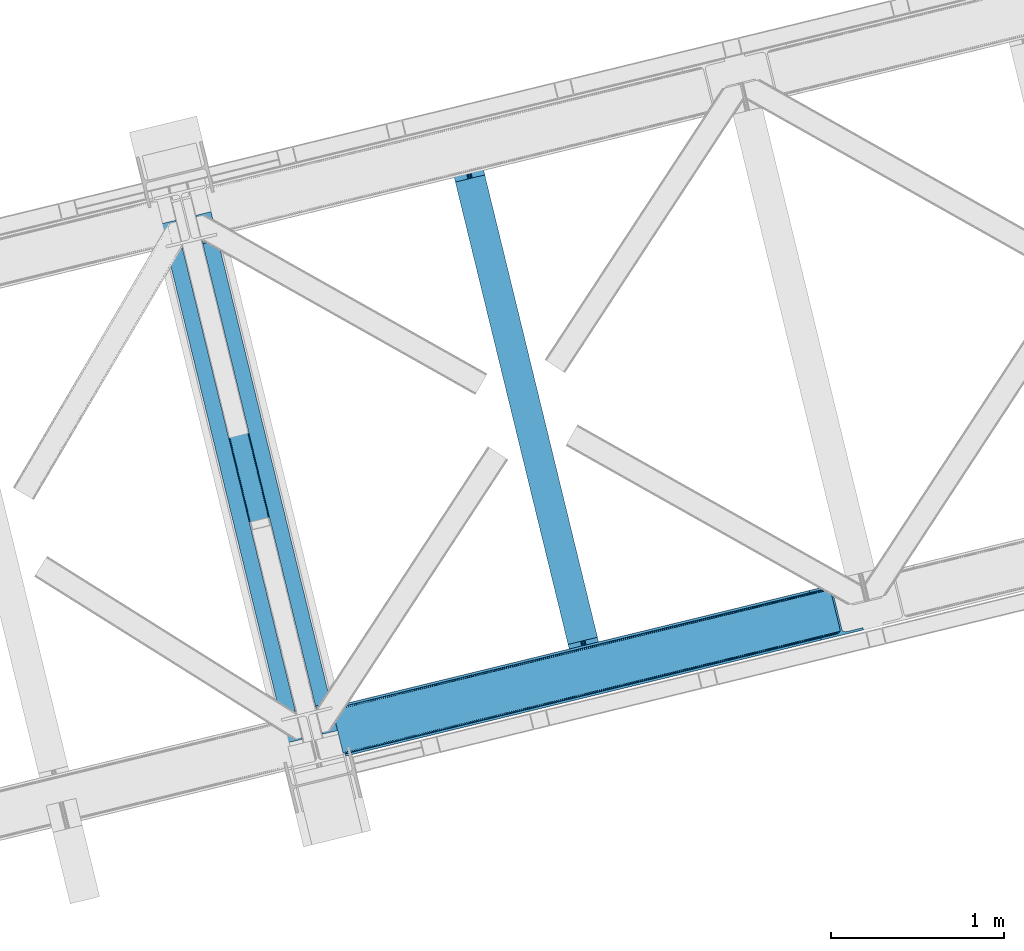
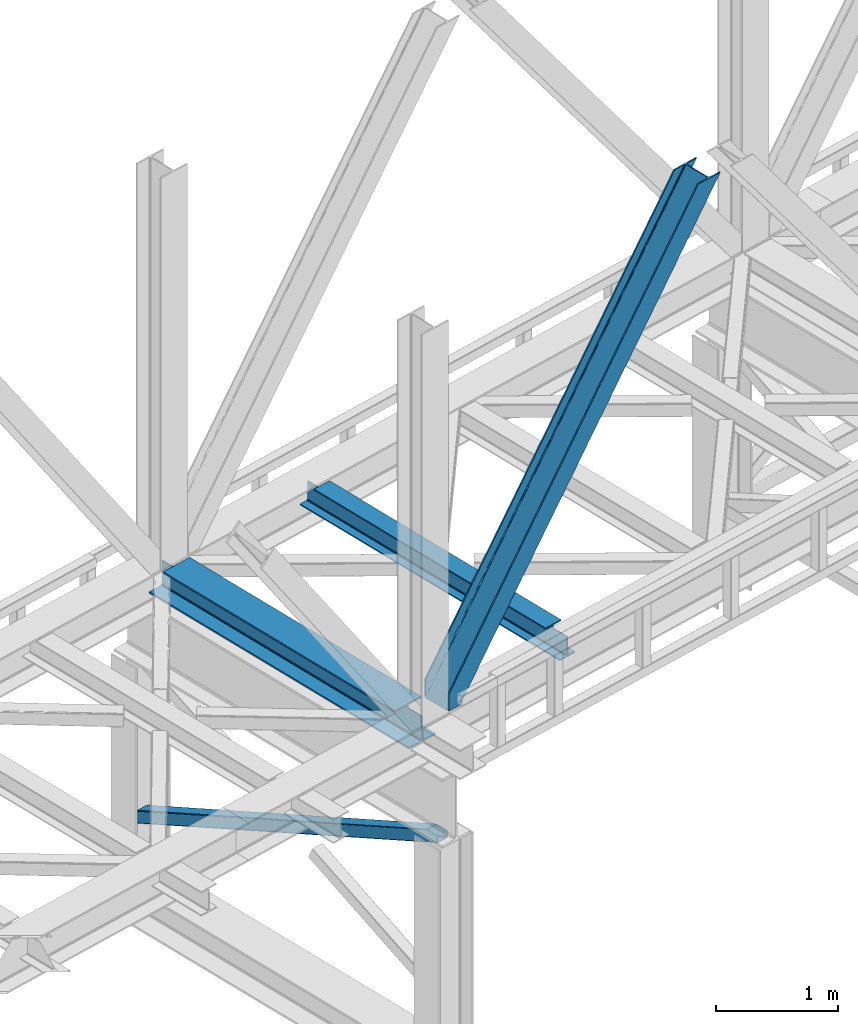
# One storey, part 38 of 92: 2 beams, 2 members.
"""IFC4 building model written with IfcOpenShell, lengths in millimetres."""

import ifcopenshell
import ifcopenshell.guid

model = None  # the IFC model being written
_history = None  # IfcOwnerHistory: only IFC2X3 demands one
_inside = {}  # id of a spatial element -> (the spatial element, [elements in it])
_under = {}  # id of a project, library or spatial element -> (it, [spatial elements below it])
_declared = {}  # id of a project -> (the project, [libraries it declares])
_typed = {}  # id of a type object -> (the type object, [elements of that type])
_made_of = {}  # id of a material, layer set ... -> (it, [elements and type objects made of it])


def new_model(schema):
    """Start an empty IFC model of exactly this schema.

    Asked for "IFC4X3", IfcOpenShell would pick the latest addendum, in which some entities
    have other attributes; the version numbers below select the first issue.
    IFC2X3 requires an IfcOwnerHistory on every rooted entity: one is made here for all.
    """
    global model, _history
    if schema == "IFC4X3":
        model = ifcopenshell.file(schema_version=(4, 3, 0, 0))
    else:
        model = ifcopenshell.file(schema=schema)
    _inside.clear()
    _under.clear()
    _declared.clear()
    _typed.clear()
    _made_of.clear()
    _history = None
    if model.schema == "IFC2X3":
        org = make("IfcOrganization", Name="unknown")
        user = make(
            "IfcPersonAndOrganization",
            ThePerson=make("IfcPerson", FamilyName="unknown"),
            TheOrganization=org,
        )
        app = make(
            "IfcApplication",
            ApplicationDeveloper=org,
            Version="unknown",
            ApplicationFullName="unknown",
            ApplicationIdentifier="unknown",
        )
        _history = make(
            "IfcOwnerHistory",
            OwningUser=user,
            OwningApplication=app,
            ChangeAction="ADDED",
            CreationDate=0,
        )
    return model


def make(cls, **values):
    """One entity of the class cls with the attributes given. An attribute that is None is left unset."""
    return model.create_entity(
        cls, **{name: value for name, value in values.items() if value is not None}
    )


def entity(cls, *values):
    """Any entity or typed value of the class cls, its attributes in the order of the schema. None: left unset."""
    e = model.create_entity(cls)
    for i, value in enumerate(values):
        if value is not None:
            e[i] = value
    return e


def rooted(cls, **values):
    """An entity with a GlobalId (a new one), such as an element, a storey or a relation."""
    return make(cls, GlobalId=ifcopenshell.guid.new(), OwnerHistory=_history, **values)


def si_unit(unit_type, name, prefix=None):
    """IfcSIUnit, for example si_unit("LENGTHUNIT", "METRE", prefix="MILLI")."""
    return make("IfcSIUnit", UnitType=unit_type, Prefix=prefix, Name=name)


def converted_unit(unit_type, name, factor, base, dimensions=None, offset=None):
    """IfcConversionBasedUnit, such as the inch: factor (a typed value) times the base unit."""
    return make(
        "IfcConversionBasedUnit"
        if offset is None
        else "IfcConversionBasedUnitWithOffset",
        ConversionOffset=offset,
        Dimensions=None
        if dimensions is None
        else entity("IfcDimensionalExponents", *dimensions),
        UnitType=unit_type,
        Name=name,
        ConversionFactor=make(
            "IfcMeasureWithUnit", ValueComponent=factor, UnitComponent=base
        ),
    )


def derived_unit(unit_type, elements):
    """IfcDerivedUnit: a product of units, each with its exponent."""
    return make(
        "IfcDerivedUnit",
        Elements=[
            make("IfcDerivedUnitElement", Unit=unit, Exponent=power)
            for unit, power in elements
        ],
        UnitType=unit_type,
    )


def assignment(units):
    """IfcUnitAssignment: the units of a project."""
    return None if units is None else make("IfcUnitAssignment", Units=units)


def point(xyz):
    """IfcCartesianPoint."""
    return None if xyz is None else make("IfcCartesianPoint", Coordinates=xyz)


def direction(xyz):
    """IfcDirection."""
    return None if xyz is None else make("IfcDirection", DirectionRatios=xyz)


def frame(location, z_axis=None, x_axis=None):
    """IfcAxis2Placement3D, a coordinate frame: its origin and axes. An axis left out is left unset."""
    return make(
        "IfcAxis2Placement3D",
        Location=point(location),
        Axis=direction(z_axis),
        RefDirection=direction(x_axis),
    )


def origin():
    """The frame at (0, 0, 0) with its axes left unset."""
    return frame((0.0, 0.0, 0.0))


def place(relative_to, where):
    """IfcLocalPlacement: puts the frame where relative to a parent placement (None: the world)."""
    return make(
        "IfcLocalPlacement", PlacementRelTo=relative_to, RelativePlacement=where
    )


def context(
    kind, dimensions, precision=None, world=None, true_north=None, identifier=None
):
    """IfcGeometricRepresentationContext, for example the 3D "Model" context."""
    return make(
        "IfcGeometricRepresentationContext",
        ContextIdentifier=identifier,
        ContextType=kind,
        CoordinateSpaceDimension=dimensions,
        Precision=precision,
        WorldCoordinateSystem=world,
        TrueNorth=true_north,
    )


def subcontext(parent, identifier, kind, view, scale=None):
    """IfcGeometricRepresentationSubContext, for example "Body" below "Model"."""
    return make(
        "IfcGeometricRepresentationSubContext",
        ContextIdentifier=identifier,
        ContextType=kind,
        ParentContext=parent,
        TargetScale=scale,
        TargetView=view,
    )


def project(units=None, contexts=None):
    """IfcProject with its units and contexts."""
    return rooted(
        "IfcProject",
        Name="project",
        RepresentationContexts=contexts,
        UnitsInContext=assignment(units),
    )


def spatial(cls, under=None, at=None, **own):
    """A site, building, storey or space (cls), placed at a placement, below another one or the project."""
    s = rooted(cls, ObjectPlacement=at, **own)
    if under is not None:
        _under.setdefault(under.id(), (under, []))[1].append(s)
    return s


def point_list(points):
    """IfcCartesianPointList2D or 3D."""
    cls = (
        "IfcCartesianPointList2D" if len(points[0]) == 2 else "IfcCartesianPointList3D"
    )
    return make(cls, CoordList=points)


def triangles(points, corners, closed=None, point_numbers=None):
    """IfcTriangulatedFaceSet: each triangle names its three corners, points numbered from 1."""
    return make(
        "IfcTriangulatedFaceSet",
        Coordinates=point_list(points),
        Closed=closed,
        CoordIndex=corners,
        PnIndex=point_numbers,
    )


def polygons(points, faces, closed=None, point_numbers=None):
    """IfcPolygonalFaceSet: a face is its outer loop, then its inner loops; points numbered from 1."""
    made = []
    for loops in faces:
        if len(loops) == 1:
            made.append(make("IfcIndexedPolygonalFace", CoordIndex=loops[0]))
        else:
            made.append(
                make(
                    "IfcIndexedPolygonalFaceWithVoids",
                    CoordIndex=loops[0],
                    InnerCoordIndices=loops[1:],
                )
            )
    return make(
        "IfcPolygonalFaceSet",
        Coordinates=point_list(points),
        Closed=closed,
        Faces=made,
        PnIndex=point_numbers,
    )


def shape(context_of_items, identifier, shape_type, items):
    """IfcShapeRepresentation: the items that make up one representation, for example the "Body"."""
    return make(
        "IfcShapeRepresentation",
        ContextOfItems=context_of_items,
        RepresentationIdentifier=identifier,
        RepresentationType=shape_type,
        Items=items,
    )


def material(Name=None, Category=None):
    """IfcMaterial."""
    return make("IfcMaterial", Name=Name, Category=Category)


def made_of(thing, what):
    """Note that an element or type object is made of a material, layer set ...; save() writes the relation."""
    if what is not None:
        _made_of.setdefault(what.id(), (what, []))[1].append(thing)
    return thing


def type_object(cls, material=None, **own):
    """A type object (cls), such as IfcWallType, which elements share."""
    return made_of(rooted(cls, **own), material)


def element(
    cls,
    number,
    at=None,
    inside=None,
    cuts=None,
    type_object=None,
    material=None,
    context=None,
    identifier="Body",
    shape_type=None,
    held_by="IfcProductDefinitionShape",
    body=None,
    shapes=None,
    **own,
):
    """One element of the class cls, such as IfcWall. Its Tag is "e" and its number.

    at: its placement. inside: the storey or other place that contains it. cuts: it is an
    opening in that element (IfcRelVoidsElement). A single representation is given by context,
    identifier, shape_type and body (its items); several are given by shapes. held_by: the class
    of the entity that holds the representations. save() writes the other relations.
    """
    e = rooted(cls, Tag="e%d" % number, ObjectPlacement=at, **own)
    if body is not None:
        shapes = [shape(context, identifier, shape_type, body)]
    if shapes is not None:
        e.Representation = make(held_by, Representations=shapes)
    if inside is not None:
        _inside.setdefault(inside.id(), (inside, []))[1].append(e)
    if cuts is not None:
        rooted(
            "IfcRelVoidsElement", RelatingBuildingElement=cuts, RelatedOpeningElement=e
        )
    if type_object is not None:
        _typed.setdefault(type_object.id(), (type_object, []))[1].append(e)
    return made_of(e, material)


def aggregate(whole, parts):
    """IfcRelAggregates: a whole, such as a stair, and the parts it consists of."""
    return rooted("IfcRelAggregates", RelatingObject=whole, RelatedObjects=parts)


def save(model, path):
    """Write the relations noted so far, then the file.

    IfcRelAggregates (storeys below a building ...), IfcRelContainedInSpatialStructure (elements
    in a storey), IfcRelDefinesByType, IfcRelAssociatesMaterial and IfcRelDeclares: one each for
    every whole, place, type object, material and project.
    """
    for whole, parts in _under.values():
        aggregate(whole, parts)
    for where, things in _inside.values():
        rooted(
            "IfcRelContainedInSpatialStructure",
            RelatedElements=things,
            RelatingStructure=where,
        )
    for kind, things in _typed.values():
        rooted("IfcRelDefinesByType", RelatedObjects=things, RelatingType=kind)
    for what, things in _made_of.values():
        rooted("IfcRelAssociatesMaterial", RelatedObjects=things, RelatingMaterial=what)
    for by, libraries in _declared.values():
        rooted("IfcRelDeclares", RelatingContext=by, RelatedDefinitions=libraries)
    model.write(path)


model = new_model("IFC4")

# Units and contexts
model_context = context("Model", 3, precision=0.01, world=origin(), true_north=direction((6.12303176911189e-17, 1.0)))
plan_context = context("Plan", 3, precision=0.01, world=origin(), true_north=direction((6.12303176911189e-17, 1.0)))
body_context = subcontext(model_context, "Body", "Model", "MODEL_VIEW")
ifc_project = project(units=[si_unit("LENGTHUNIT", "METRE", prefix="MILLI"), si_unit("AREAUNIT", "SQUARE_METRE"), si_unit("VOLUMEUNIT", "CUBIC_METRE"), converted_unit("PLANEANGLEUNIT", "DEGREE", entity("IfcRatioMeasure", 0.0174532925199433), si_unit("PLANEANGLEUNIT", "RADIAN"), dimensions=[0, 0, 0, 0, 0, 0, 0]), si_unit("MASSUNIT", "GRAM", prefix="KILO"), derived_unit("MASSDENSITYUNIT", [(si_unit("MASSUNIT", "GRAM", prefix="KILO"), 1), (si_unit("LENGTHUNIT", "METRE"), -3)]), derived_unit("MOMENTOFINERTIAUNIT", [(si_unit("LENGTHUNIT", "METRE"), 4)]), si_unit("TIMEUNIT", "SECOND"), si_unit("FREQUENCYUNIT", "HERTZ"), si_unit("THERMODYNAMICTEMPERATUREUNIT", "DEGREE_CELSIUS"), derived_unit("THERMALTRANSMITTANCEUNIT", [(si_unit("MASSUNIT", "GRAM", prefix="KILO"), 1), (si_unit("THERMODYNAMICTEMPERATUREUNIT", "KELVIN"), -1), (si_unit("TIMEUNIT", "SECOND"), -3)]), derived_unit("VOLUMETRICFLOWRATEUNIT", [(si_unit("LENGTHUNIT", "METRE"), 3), (si_unit("TIMEUNIT", "SECOND"), -1)]), derived_unit("MASSFLOWRATEUNIT", [(si_unit("MASSUNIT", "GRAM", prefix="KILO"), 1), (si_unit("TIMEUNIT", "SECOND"), -1)]), derived_unit("ROTATIONALFREQUENCYUNIT", [(si_unit("TIMEUNIT", "SECOND"), -1)]), si_unit("ELECTRICCURRENTUNIT", "AMPERE"), si_unit("ELECTRICVOLTAGEUNIT", "VOLT"), si_unit("POWERUNIT", "WATT"), si_unit("FORCEUNIT", "NEWTON", prefix="KILO"), si_unit("ILLUMINANCEUNIT", "LUX"), si_unit("LUMINOUSFLUXUNIT", "LUMEN"), si_unit("LUMINOUSINTENSITYUNIT", "CANDELA"), derived_unit("USERDEFINED", [(si_unit("MASSUNIT", "GRAM", prefix="KILO"), -1), (si_unit("LENGTHUNIT", "METRE"), -2), (si_unit("TIMEUNIT", "SECOND"), 3), (si_unit("LUMINOUSFLUXUNIT", "LUMEN"), 1)]), derived_unit("LINEARVELOCITYUNIT", [(si_unit("LENGTHUNIT", "METRE"), 1), (si_unit("TIMEUNIT", "SECOND"), -1)]), si_unit("PRESSUREUNIT", "PASCAL"), derived_unit("USERDEFINED", [(si_unit("LENGTHUNIT", "METRE"), -2), (si_unit("MASSUNIT", "GRAM", prefix="KILO"), 1), (si_unit("TIMEUNIT", "SECOND"), -2)]), derived_unit("LINEARFORCEUNIT", [(si_unit("MASSUNIT", "GRAM", prefix="KILO"), 1), (si_unit("LENGTHUNIT", "METRE"), 1), (si_unit("TIMEUNIT", "SECOND"), -2), (si_unit("LENGTHUNIT", "METRE"), -1)]), derived_unit("PLANARFORCEUNIT", [(si_unit("MASSUNIT", "GRAM", prefix="KILO"), 1), (si_unit("LENGTHUNIT", "METRE"), 1), (si_unit("TIMEUNIT", "SECOND"), -2), (si_unit("LENGTHUNIT", "METRE"), -2)])], contexts=[model_context, plan_context])

# Site, building, storey
site_placement = place(None, origin())
site = spatial("IfcSite", under=ifc_project, at=site_placement, CompositionType="ELEMENT")
building_placement = place(site_placement, origin())
building = spatial("IfcBuilding", under=site, at=building_placement, CompositionType="ELEMENT")
storey_placement = place(building_placement, frame((0.0, 0.0, 15900.0)))
storey = spatial("IfcBuildingStorey", under=building, at=storey_placement, Name="05", CompositionType="ELEMENT", Elevation=15900.0)

# Beams
ifc_material = material(Name="Metal painted (White)")
beam_type = type_object("IfcBeamType", PredefinedType="BEAM")
beam_1_placement = place(storey_placement, frame((-49495.31, 5721.7, 3385.0)))
element("IfcBeam", 1, at=beam_1_placement, inside=storey, type_object=beam_type, material=ifc_material, ObjectType="Steel Beam", PredefinedType="BEAM", context=body_context, shape_type="Tessellation", body=[
    polygons([(1022.42935345713, 71.0478278971021, 15.4999999999986), (1022.42935345713, 71.0478278971021, 0.0), (291.465617442446, 3069.74325535076, 0.0), (291.465617442455, 3069.74325535076, 15.4999999999986), (899.04224207317, 40.9709140873291, 15.4999999999986), (168.078506058491, 3039.66634154099, 15.4999999999986), (892.349898299208, 39.3395844888232, 16.8701684147963), (161.386162284528, 3038.03501194248, 16.8701684147963), (886.676403198592, 37.956610033653, 20.7720779386413), (155.712667183913, 3036.65203748731, 20.7720779386413), (882.885494970017, 37.0325360459173, 26.6116982174294), (151.921758955338, 3035.72796349958, 26.6116982174294), (881.554305026612, 36.708044413504, 33.500000000001), (150.590569011941, 3035.40347186716, 33.500000000001), (140.875048430522, 3033.03521093726, 33.500000000001), (140.875048430522, 3033.03521093726, 259.000000000002), (150.590569011932, 3035.40347186716, 259.000000000002), (0.0, 2998.69542745366, 0.0), (0.0, 2998.69542745366, 15.4999999999986), (123.387111383972, 3028.77234126343, 15.4999999999986), (130.079455157926, 3030.40367086194, 16.8701684147963), (135.752950258551, 3031.78664531711, 20.7720779386413), (139.543858487135, 3032.71071930484, 26.6116982174294), (881.554305026612, 36.708044413504, 259.000000000002), (871.838784445202, 34.3397834835992, 259.000000000002), (871.838784445202, 34.3397834836003, 33.500000000001), (870.507594501796, 34.0152918511837, 26.6116982174294), (866.716686273221, 33.0912178634492, 20.7720779386413), (861.043191172606, 31.7082434082778, 16.8701684147963), (854.350847398643, 30.076913809773, 15.4999999999986), (730.963736014679, 0.0, 15.4999999999986), (730.963736014679, 0.0, 0.0), (841.85453458624, 199.571930111231, 259.069791776412), (190.199733064572, 2872.911390143, 259.000000000002), (190.423126166413, 2871.99494573803, 259.61730333112), (190.435515010047, 2871.94412150426, 266.500003008253), (841.70935577274, 200.167408132525, 266.500002998871), (841.709705893492, 200.16597182779, 260.000004007589), (832.229597305445, 196.831858094285, 259.006343172366), (832.006227290721, 197.74830961273, 259.61730333112), (831.993838447078, 197.799133846505, 266.500003008253), (180.719997684385, 2869.57584721824, 266.500002998871), (180.719647563633, 2869.57728352297, 260.000004007589), (180.574841905298, 2870.17133233676, 259.07612046749), (180.484212483145, 2870.5431292131, 259.000000000002), (843.040843642667, 200.490677577209, 273.388305639783), (846.831120231363, 201.417342749122, 279.227924098781), (852.504191178902, 202.802057212798, 283.129832400615), (859.196382860027, 204.434010743612, 284.500000377228), (982.583411547871, 234.511263798724, 284.500000138971), (982.581741741219, 234.518113867455, 299.999995328161), (691.11631964394, 163.469484603412, 299.999995890962), (691.1179894506, 163.46263453468, 284.500000701776), (814.505018138444, 193.539887589791, 284.500000463519), (821.197505034583, 195.17063005637, 283.129832461069), (826.871416683352, 196.551895700895, 279.227924137322), (830.662951470335, 197.473399350194, 273.388305663684), (179.38850981445, 2869.25257777355, 273.388305639783), (175.598233225762, 2868.32591260164, 279.227924098781), (169.925162278224, 2866.94119813796, 283.129832400619), (163.232970597099, 2865.30924460715, 284.500000377228), (39.8459419092548, 2835.23199155204, 284.500000138971), (39.8476117159152, 2835.22514148331, 299.999995328161), (331.313033813185, 2906.27377074735, 299.999995890962), (331.311364006525, 2906.28062081608, 284.500000701776), (207.92433531869, 2876.20336776097, 284.500000463519), (201.231848422542, 2874.57262529439, 283.129832461065), (195.557936773782, 2873.19135964986, 279.227924137322), (191.76640198679, 2872.26985600057, 273.388305663684)], [[[1, 2, 3, 4]], [[5, 1, 4, 6]], [[7, 5, 6, 8]], [[9, 7, 8, 10]], [[11, 9, 10, 12]], [[13, 11, 12, 14]], [[15, 16, 17, 14, 12, 10, 8, 6, 4, 3, 18, 19, 20, 21, 22, 23]], [[13, 24, 25, 26, 27, 28, 29, 30, 31, 32, 2, 1, 5, 7, 9, 11]], [[2, 32, 18, 3]], [[32, 31, 19, 18]], [[31, 30, 20, 19]], [[27, 26, 15, 23]], [[28, 27, 23, 22]], [[29, 28, 22, 21]], [[30, 29, 21, 20]], [[33, 24, 13, 14, 17, 34, 35, 36, 37, 38]], [[25, 39, 40, 41, 42, 43, 44, 16, 15, 26]], [[39, 25, 24, 33]], [[45, 34, 17, 16]], [[41, 40, 38, 37, 46, 47, 48, 49, 50, 51, 52, 53, 54, 55, 56, 57]], [[42, 58, 59, 60, 61, 62, 63, 64, 65, 66, 67, 68, 69, 36, 35, 43]], [[46, 37, 36, 69]], [[47, 46, 69, 68]], [[48, 47, 68, 67]], [[49, 48, 67, 66]], [[50, 49, 66, 65]], [[51, 50, 65, 64]], [[52, 51, 64, 63]], [[53, 52, 63, 62]], [[54, 53, 62, 61]], [[55, 54, 61, 60]], [[56, 55, 60, 59]], [[57, 56, 59, 58]], [[41, 57, 58, 42]]], closed=False),
])
beam_2_placement = place(storey_placement, frame((-47831.53, 6127.26, 3441.0)))
element("IfcBeam", 2, at=beam_2_placement, inside=storey, type_object=beam_type, material=ifc_material, ObjectType="Steel Beam", PredefinedType="BEAM", context=body_context, shape_type="Tessellation", body=[
    polygons([(900.98534618944, 41.4445662733081, 11.000000000004), (900.98534618944, 41.4445662733081, 2.16573425859679e-12), (170.021610174761, 3040.13999372697, 2.16573425859679e-12), (170.021610174761, 3040.13999372697, 11.000000000004), (834.919806235823, 25.3403919499656, 11.000000000004), (103.956070221144, 3024.03581940362, 11.000000000004), (828.971056214531, 23.8903211957396, 12.2179274798217), (98.0073201998513, 3022.5857486494, 12.2179274798217), (823.927949458422, 22.6610105689183, 15.6862915010192), (92.9642134437427, 3021.35643802258, 15.6862915010192), (820.558253255246, 21.8396114687108, 20.8770650821657), (89.5945172405668, 3020.53503892237, 20.8770650821657), (819.37497330556, 21.5511744621195, 27.0000000000047), (88.4112372908809, 3020.24660191578, 27.0000000000047), (81.6103728838888, 3018.58881926485, 27.0000000000047), (81.6103728838888, 3018.58881926485, 203.000000000006), (88.4112372908809, 3020.24660191578, 203.000000000006), (8.66293703438714e-12, 2998.69542745366, 2.16573425859679e-12), (8.66293703438714e-12, 2998.69542745366, 10.9999999999997), (66.0655399536259, 3014.799601777, 11.000000000004), (72.014289974927, 3016.24967253123, 12.2179274798217), (77.057396731027, 3017.47898315805, 15.6862915010192), (80.4270929342029, 3018.30038225826, 20.8770650821657), (819.374973305552, 21.5511744621206, 203.000000000006), (812.574108898559, 19.8933918111876, 203.000000000006), (812.574108898559, 19.8933918111876, 27.0000000000047), (811.390828948873, 19.6049548045974, 20.8770650821657), (808.021132745698, 18.7835557043887, 15.6862915010192), (802.978025989598, 17.5542450775685, 12.2179274798217), (797.029275968296, 16.1041743233425, 11.000000000004), (730.963736014679, -1.08286712929839e-12, 10.9999999999997), (730.963736014679, -1.08286712929839e-12, 2.16573425859679e-12), (779.675212882757, 184.415062601693, 203.069791966819), (128.020401343512, 2857.75452019162, 203.000000000006), (128.243282132658, 2856.84017775719, 203.617301946336), (128.256196377177, 2856.7871977843, 217.000003693143), (779.530009633833, 185.010597404072, 217.000003676718), (779.530880241731, 185.007025963192, 204.00000679514), (772.96491171832, 182.385463974442, 203.006342981529), (772.742064056782, 183.299815969774, 203.617301946336), (772.729149812263, 183.352795942667, 217.000003693143), (121.455336555608, 2855.1293963229, 217.000003676718), (121.45446594771, 2855.13296776378, 204.00000679514), (121.310166358664, 2855.72494066435, 203.076120467494), (121.21953693652, 2856.09673754069, 203.000000000006), (780.713494357868, 185.298194377513, 223.122939328039), (784.082490766547, 186.122464201392, 228.313710402595), (789.125126170571, 187.353708426697, 231.782072735464), (795.073705041275, 188.80448128138, 232.999999602236), (861.13915590679, 204.909021065315, 232.999999283132), (861.137682570361, 204.915065042187, 243.999994005812), (691.11630166644, 163.469558245297, 243.999994827032), (691.117775002877, 163.463514268423, 233.000000104353), (757.183225868401, 179.568054052358, 232.999999785253), (763.132130996731, 181.017488520583, 231.782072861016), (768.17569550387, 182.244921343717, 228.313710479427), (771.546082413602, 183.063487001148, 223.12293937232), (120.271851831572, 2854.84179934945, 223.122939328039), (116.902855422893, 2854.01752952557, 228.313710402595), (111.860220018869, 2852.78628530027, 231.782072735464), (105.911641148165, 2851.33551244559, 232.999999602236), (39.8461902826505, 2835.23097266165, 232.999999283128), (39.8476636190881, 2835.22492868478, 243.999994005812), (209.869044523001, 2876.67043548167, 243.999994827032), (209.867571186563, 2876.67647945854, 233.000000104357), (143.80212032104, 2860.57193967461, 232.999999785253), (137.85321519271, 2859.12250520638, 231.782072861012), (132.809650685579, 2857.89507238325, 228.313710479427), (129.439263775838, 2857.07650672582, 223.12293937232)], [[[1, 2, 3, 4]], [[5, 1, 4, 6]], [[7, 5, 6, 8]], [[9, 7, 8, 10]], [[11, 9, 10, 12]], [[13, 11, 12, 14]], [[15, 16, 17, 14, 12, 10, 8, 6, 4, 3, 18, 19, 20, 21, 22, 23]], [[13, 24, 25, 26, 27, 28, 29, 30, 31, 32, 2, 1, 5, 7, 9, 11]], [[2, 32, 18, 3]], [[32, 31, 19, 18]], [[31, 30, 20, 19]], [[27, 26, 15, 23]], [[28, 27, 23, 22]], [[29, 28, 22, 21]], [[30, 29, 21, 20]], [[33, 24, 13, 14, 17, 34, 35, 36, 37, 38]], [[25, 39, 40, 41, 42, 43, 44, 16, 15, 26]], [[39, 25, 24, 33]], [[45, 34, 17, 16]], [[41, 40, 38, 37, 46, 47, 48, 49, 50, 51, 52, 53, 54, 55, 56, 57]], [[42, 58, 59, 60, 61, 62, 63, 64, 65, 66, 67, 68, 69, 36, 35, 43]], [[46, 37, 36, 69]], [[47, 46, 69, 68]], [[48, 47, 68, 67]], [[49, 48, 67, 66]], [[50, 49, 66, 65]], [[51, 50, 65, 64]], [[52, 51, 64, 63]], [[53, 52, 63, 62]], [[54, 53, 62, 61]], [[55, 54, 61, 60]], [[56, 55, 60, 59]], [[57, 56, 59, 58]], [[41, 57, 58, 42]]], closed=False),
])

# Members
member_type_1 = type_object("IfcMemberType", PredefinedType="BRACE")
member_1_placement = place(storey_placement, frame((-48501.69, 5645.25, 3695.0)))
element("IfcMember", 3, at=member_1_placement, inside=storey, type_object=member_type_1, ObjectType="Steel Vertical Brace", PredefinedType="BRACE", context=body_context, shape_type="Tessellation", body=[
    triangles([(58.5313110351563, 27.8802749633796, 0.0), (60.4474731445298, 20.0011047363287, 0.0), (59.0987182617173, 20.928955078125, 0.827856445310317), (58.9684936523408, 19.7534454345705, 1.13248901367115), (72.2095458984331, 11.6585906982427, 0.0), (71.3956420898394, 13.9003143310547, 30.563250732419), (70.228271484375, 15.4356857299808, 25.1542785644524), (72.2095458984331, 11.6585906982427, 171.175598144531), (71.9304931640581, 12.6195785522468, 42.2602111816377), (71.9304931640581, 12.6195785522468, 171.115136718749), (70.3910522460938, 15.5600967407227, 0.0), (68.8190551757798, 17.2873168945316, 18.6337463378877), (67.2145019531235, 18.4651519775398, 14.6921264648408), (63.168237304686, 19.9295974731449, 7.29955444335792), (63.168237304686, 19.9295974731449, 0.0), (67.2145019531235, 18.4651519775398, 0.0), (2821.28360595703, 682.803089904785, 3911.00081176758), (2916.00805664063, 705.89354095459, 3911.00081176758), (2933.63488769531, 721.628045654297, 3911.00081176758), (2930.26765136718, 714.795904541016, 3911.00081176758), (2933.67209472656, 728.727030944825, 3911.00081176758), (2924.07733154297, 709.270660400391, 3911.00081176758), (2824.35783691406, 670.173046875, 3911.00081176758), (75.0512329101548, 0.0, 171.175598144531), (75.0512329101548, 0.0, 0.0), (192.881249999999, 28.7226654052738, 0.0), (3068.02668457031, 729.569421386719, 3911.00081176758), (3064.94780273437, 742.199464416504, 3911.00081176758), (189.802368164063, 41.352708435059, 0.0), (2970.22335205078, 719.109594726563, 3911.00081176758), (95.0779174804702, 18.2622573852541, 0.0), (2961.50760498047, 718.394522094727, 3911.00081176758), (86.3621704101533, 17.5477661132818, 0.0), (2953.46623535156, 720.451373291016, 3911.00081176758), (78.32080078125, 19.6040359497074, 0.0), (2947.33172607422, 724.966213989258, 3911.00081176758), (72.1862915039019, 24.1188766479499, 0.0), (2944.02960205078, 731.251295471192, 3911.00081176758), (68.8841674804644, 30.4045394897466, 0.0), (2888.85157470703, 957.622943115235, 3911.00081176758), (13.7061401367173, 256.77618713379, 0.0), (2888.88878173828, 964.722509765626, 3911.00081176758), (13.7433471679688, 263.875172424317, 0.0), (2892.25601806641, 971.554650878907, 3911.00081176758), (17.115234375, 270.707313537598, 0.0), (2898.44633789062, 977.079895019531, 3911.00081176758), (23.3055541992144, 276.232557678223, 0.0), (2906.51561279297, 980.457014465333, 3911.00081176758), (31.3701782226563, 279.609677124024, 0.0), (3001.24471435547, 1003.54688415527, 3911.00081176758), (126.099279785158, 302.700128173828, 0.0), (2998.16583251953, 1016.17750854492, 3911.00081176758), (123.020397949214, 315.330171203614, 0.0), (2878.49406738281, 955.098678588867, 3911.00081176758), (3.3486328125, 254.251922607422, 0.0), (2869.05743408203, 965.899182128906, 3911.00081176758), (2861.01606445312, 967.955451965332, 3911.00081176758), (2754.49698486328, 956.78055267334, 3911.00081176758), (2852.30031738281, 967.24096069336, 3911.00081176758), (2757.57586669922, 944.150509643555, 3911.00081176758), (2875.19194335937, 961.384341430665, 3911.00081176758), (5.18572998046875, 286.60750579834, 171.175598144531), (5.18572998046875, 286.60750579834, 0.0), (8.02741699218313, 274.948915100098, 171.175598144531), (8.22275390625146, 273.966998291016, 171.115136718749), (8.22275390625146, 273.966998291016, 42.2602111816377), (8.02741699218313, 274.948915100098, 0.0), (3.80906982421584, 263.445547485352, 0.0), (6.72982177734229, 266.608145141602, 0.0), (8.21345214843313, 270.64917755127, 0.0), (1.42781982421729, 262.13051147461, 0.0), (3.80906982421584, 263.445547485352, 7.29955444335792), (8.33902587890771, 272.585105895996, 30.563250732419), (8.21345214843313, 270.64917755127, 24.1799194335908), (7.30653076171438, 268.181886291504, 18.3872497558586), (6.72982177734229, 266.608145141602, 14.6921264648408), (0.0, 261.670074462891, 1.13248901367115), (0.655773925776884, 260.685250854493, 0.827856445310317)], [[1, 2, 3], [4, 3, 2], [5, 6, 7], [5, 8, 9], [10, 9, 8], [9, 6, 5], [11, 12, 13], [11, 7, 12], [14, 4, 2], [2, 15, 14], [16, 13, 14], [14, 15, 16], [13, 16, 11], [7, 11, 5], [17, 18, 10], [9, 10, 18], [19, 3, 14], [14, 20, 19], [14, 13, 20], [13, 12, 20], [3, 4, 14], [19, 21, 1], [1, 3, 19], [6, 20, 7], [6, 22, 20], [12, 7, 20], [18, 22, 9], [6, 9, 22], [8, 17, 10], [23, 8, 24], [8, 23, 17], [25, 24, 5], [8, 5, 24], [23, 26, 27], [26, 23, 24], [25, 26, 24], [28, 27, 29], [26, 29, 27], [30, 28, 29], [29, 31, 30], [32, 30, 31], [31, 33, 32], [34, 32, 33], [33, 35, 34], [36, 34, 35], [35, 37, 36], [38, 36, 37], [37, 39, 38], [40, 38, 39], [39, 41, 40], [42, 40, 43], [41, 43, 40], [44, 42, 45], [43, 45, 42], [46, 44, 47], [45, 47, 44], [48, 46, 49], [47, 49, 46], [50, 48, 51], [49, 51, 48], [52, 50, 53], [51, 53, 50], [21, 54, 55], [55, 1, 21], [54, 21, 40], [20, 22, 32], [18, 23, 27], [17, 23, 18], [22, 18, 30], [21, 19, 36], [19, 20, 34], [56, 46, 57], [58, 59, 52], [59, 57, 48], [58, 60, 59], [56, 61, 44], [61, 54, 42], [40, 21, 38], [30, 32, 22], [36, 19, 34], [32, 34, 20], [36, 38, 21], [27, 30, 18], [27, 28, 30], [48, 57, 46], [44, 61, 42], [40, 42, 54], [44, 46, 56], [48, 52, 59], [52, 48, 50], [58, 53, 62], [58, 52, 53], [53, 63, 62], [64, 58, 62], [60, 64, 65], [64, 60, 58], [59, 60, 65], [65, 66, 59], [67, 64, 62], [62, 63, 67], [11, 35, 5], [68, 41, 55], [69, 70, 43], [69, 43, 68], [55, 71, 68], [67, 63, 47], [67, 45, 70], [55, 39, 1], [37, 16, 15], [2, 1, 15], [15, 1, 39], [11, 16, 37], [25, 5, 33], [39, 55, 41], [49, 47, 63], [43, 70, 45], [47, 45, 67], [43, 41, 68], [53, 49, 63], [53, 51, 49], [31, 25, 33], [35, 11, 37], [39, 37, 15], [35, 33, 5], [31, 26, 25], [26, 31, 29], [72, 68, 71], [67, 73, 66], [67, 70, 74], [74, 73, 67], [64, 67, 66], [66, 65, 64], [75, 70, 76], [75, 74, 70], [69, 76, 70], [76, 69, 72], [68, 72, 69], [71, 77, 72], [78, 61, 72], [61, 56, 75], [75, 76, 61], [76, 72, 61], [56, 57, 73], [73, 74, 56], [57, 59, 66], [66, 73, 57], [74, 75, 56], [72, 77, 78], [54, 61, 55], [78, 55, 61], [71, 55, 78], [78, 77, 71]]),
])
member_type_2 = type_object("IfcMemberType", PredefinedType="BRACE")
member_2_placement = place(storey_placement, frame((-49464.95, 5508.87, 911.28)))
element("IfcMember", 4, at=member_2_placement, inside=storey, type_object=member_type_2, ObjectType="Steel Vertical Brace", PredefinedType="BRACE", context=body_context, shape_type="Tessellation", body=[
    triangles([(109.783996582031, 3493.74488525391, 0.0), (954.899853515628, 26.761738586426, 1610.78191223144), (6.79958496093604, 3468.64118499756, 0.0), (851.915441894533, 1.65803833007885, 1610.78191223144), (112.188500976561, 3494.3308959961, 1.12551269531104), (957.304357910158, 27.3477493286136, 1611.90626220703), (114.593005371091, 3494.91748809815, 2.24986267089844), (959.708862304688, 27.9337600708013, 1613.03061218261), (115.588293457033, 3495.15991516113, 4.96481323242188), (960.704150390622, 28.1761871337894, 1615.74672546387), (116.583581542967, 3495.40292358399, 7.68092651366896), (961.699438476564, 28.4191955566412, 1618.46167602539), (0.99528808593459, 3467.22615509033, 4.96481323242188), (846.106494140622, 0.243008422851744, 1615.74672546387), (0.0, 3466.98372802735, 7.68092651366896), (845.111206054688, 0.0, 1618.46167602539), (1.99057617187646, 3467.46916351318, 2.24986267089844), (847.106433105466, 0.486016845703489, 1613.03061218261), (4.39508056640625, 3468.05575561524, 1.12551269531104), (849.510937500003, 1.07202758789117, 1611.90626220703), (933.347680664061, 144.732444763184, 1680.7206665039), (116.583581542967, 3495.40292358399, 123.979641723632), (961.699438476564, 28.4191955566412, 1680.7206665039), (816.759448242185, 116.313830566407, 1680.7206665039), (0.0, 3466.98372802735, 123.979641723632), (845.111206054688, 0.0, 1680.7206665039), (112.188500976561, 3494.3308959961, 130.53505554199), (109.783996582031, 3493.74488525391, 131.659405517577), (922.515783691408, 159.605374145508, 1680.7206665039), (114.593005371091, 3494.91748809815, 129.409542846679), (925.427233886716, 158.981575012207, 1680.7206665039), (115.588293457033, 3495.15991516113, 126.694592285156), (928.506115722659, 155.935830688477, 1680.7206665039), (931.287341308591, 150.932647705078, 1680.7206665039), (6.79958496093604, 3468.64118499756, 131.659405517577), (819.531372070313, 134.501673889161, 1680.7206665039), (815.73625488281, 122.765762329102, 1680.7206665039), (0.99528808593459, 3467.22615509033, 126.694592285156), (815.903686523438, 128.488087463379, 1680.7206665039), (1.99057617187646, 3467.46916351318, 129.409542846679), (817.233837890628, 132.608766174317, 1680.7206665039), (4.39508056640625, 3468.05575561524, 130.53505554199), (923.445959472658, 145.989926147461, 1680.7206665039), (926.524841308594, 142.944181823731, 1680.7206665039), (920.534509277342, 146.613725280762, 1680.7206665039), (931.366406250003, 131.741377258301, 1680.7206665039), (956.839270019533, 27.2349655151374, 1680.7206665039), (929.306066894533, 137.940998840332, 1680.7206665039), (823.638098144533, 117.864317321778, 1680.7206665039), (824.972900390625, 121.986158752442, 1680.7206665039), (827.265783691408, 123.878485107422, 1680.7206665039), (824.49385986328, 105.690641784669, 1680.7206665039), (823.470666503905, 112.142573547364, 1680.7206665039), (849.971374511719, 1.18423004150463, 1680.7206665039), (111.728063964845, 3494.21869354248, 118.492767333984), (110.732775878903, 3493.97568511963, 121.208880615231), (109.73283691406, 3493.73325805664, 123.923831176755), (107.332983398439, 3493.14724731445, 125.048181152342), (104.923828125, 3492.5606552124, 126.173693847653), (11.6551025390654, 3469.82541503906, 126.173693847653), (9.25059814452834, 3469.23940429688, 125.048181152342), (6.84609374999854, 3468.65339355469, 123.923831176755), (5.85080566406396, 3468.4109664917, 121.208880615231), (4.85551757812209, 3468.16795806885, 118.492767333984), (111.728063964845, 3494.21869354248, 13.166638183593), (956.839270019533, 27.2349655151374, 1623.94738769531), (4.85551757812209, 3468.16795806885, 13.166638183593), (849.971374511719, 1.18423004150463, 1623.94738769531), (109.73283691406, 3493.73325805664, 7.73557434081886), (107.332983398439, 3493.14724731445, 6.61122436523146), (110.732775878903, 3493.97568511963, 10.4505249023423), (104.923828125, 3492.5606552124, 5.48571166992042), (6.84609374999854, 3468.65339355469, 7.73557434081886), (5.85080566406396, 3468.4109664917, 10.4505249023423), (9.25059814452834, 3469.23940429688, 6.61122436523146), (11.6551025390654, 3469.82541503906, 5.48571166992042), (950.039685058597, 25.5775085449222, 1616.26762390137), (952.444189453126, 26.1635192871099, 1617.39197387695), (954.848693847656, 26.7495300292976, 1618.51748657227), (856.770959472655, 2.84226837158258, 1616.26762390137), (854.366455078125, 2.2562576293949, 1617.39197387695), (851.961950683595, 1.66966552734448, 1618.51748657227), (955.843981933591, 26.9925384521484, 1621.23243713379), (850.966662597653, 1.42723846435547, 1621.23243713379)], [[1, 2, 3], [4, 3, 2], [5, 6, 2], [2, 1, 5], [7, 8, 6], [6, 5, 7], [9, 10, 8], [8, 7, 9], [11, 12, 10], [10, 9, 11], [13, 14, 15], [16, 15, 14], [17, 18, 13], [14, 13, 18], [19, 20, 17], [18, 17, 20], [3, 4, 19], [20, 19, 4], [11, 21, 12], [21, 11, 22], [23, 12, 21], [24, 15, 16], [24, 25, 15], [16, 26, 24], [27, 28, 29], [30, 27, 31], [32, 30, 33], [22, 32, 34], [34, 21, 22], [33, 34, 32], [31, 33, 30], [29, 31, 27], [29, 28, 35], [35, 36, 29], [25, 24, 37], [38, 37, 39], [40, 39, 41], [42, 41, 36], [36, 35, 42], [41, 42, 40], [39, 40, 38], [37, 38, 25], [43, 44, 34], [33, 43, 34], [29, 33, 31], [45, 29, 36], [33, 45, 43], [29, 45, 33], [44, 21, 34], [23, 46, 47], [23, 21, 46], [44, 48, 21], [48, 46, 21], [37, 49, 50], [36, 51, 45], [51, 39, 50], [39, 51, 36], [50, 39, 37], [39, 36, 41], [24, 49, 37], [52, 53, 24], [53, 49, 24], [52, 26, 54], [24, 26, 52], [55, 46, 48], [56, 48, 44], [57, 44, 43], [58, 43, 45], [45, 59, 58], [43, 58, 57], [44, 57, 56], [48, 56, 55], [59, 45, 51], [51, 60, 59], [61, 60, 51], [62, 61, 50], [63, 62, 49], [64, 63, 53], [53, 52, 64], [49, 53, 63], [50, 49, 62], [51, 50, 61], [46, 65, 66], [46, 55, 65], [66, 47, 46], [67, 52, 68], [52, 67, 64], [54, 68, 52], [58, 59, 28], [32, 57, 27], [32, 27, 30], [28, 59, 35], [28, 27, 58], [57, 58, 27], [55, 22, 11], [22, 56, 57], [55, 56, 22], [22, 57, 32], [42, 62, 38], [60, 35, 59], [61, 42, 35], [61, 35, 60], [38, 40, 42], [62, 25, 38], [42, 61, 62], [62, 63, 25], [25, 64, 15], [64, 25, 63], [69, 5, 70], [11, 65, 55], [71, 11, 69], [11, 71, 65], [69, 11, 9], [70, 1, 72], [69, 9, 5], [5, 9, 7], [72, 1, 3], [5, 1, 70], [73, 13, 15], [74, 73, 15], [75, 19, 73], [67, 15, 64], [15, 67, 74], [19, 13, 73], [3, 76, 72], [19, 75, 3], [76, 3, 75], [17, 13, 19], [77, 4, 2], [2, 6, 78], [6, 8, 10], [6, 79, 78], [2, 78, 77], [79, 6, 10], [80, 4, 77], [18, 20, 14], [20, 4, 81], [81, 82, 20], [20, 82, 14], [80, 81, 4], [14, 82, 16], [83, 12, 66], [10, 12, 79], [83, 79, 12], [23, 66, 12], [23, 47, 66], [16, 84, 68], [84, 16, 82], [68, 26, 16], [26, 68, 54], [77, 72, 76], [76, 80, 77], [66, 65, 83], [71, 83, 65], [83, 71, 79], [69, 79, 71], [79, 69, 78], [70, 78, 69], [78, 70, 77], [72, 77, 70], [80, 76, 75], [75, 81, 80], [81, 75, 73], [73, 82, 81], [82, 73, 74], [74, 84, 82], [84, 74, 67], [67, 68, 84]]),
])

save(model, "model.ifc")
